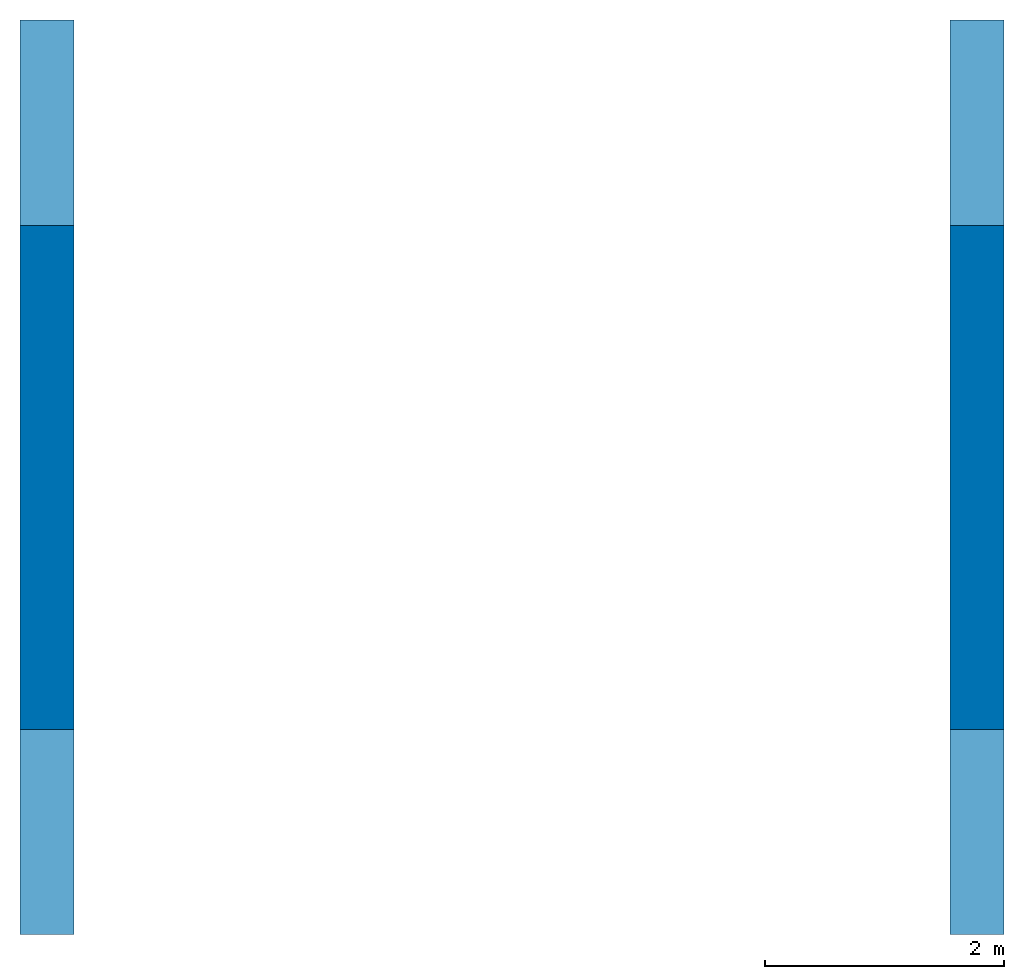
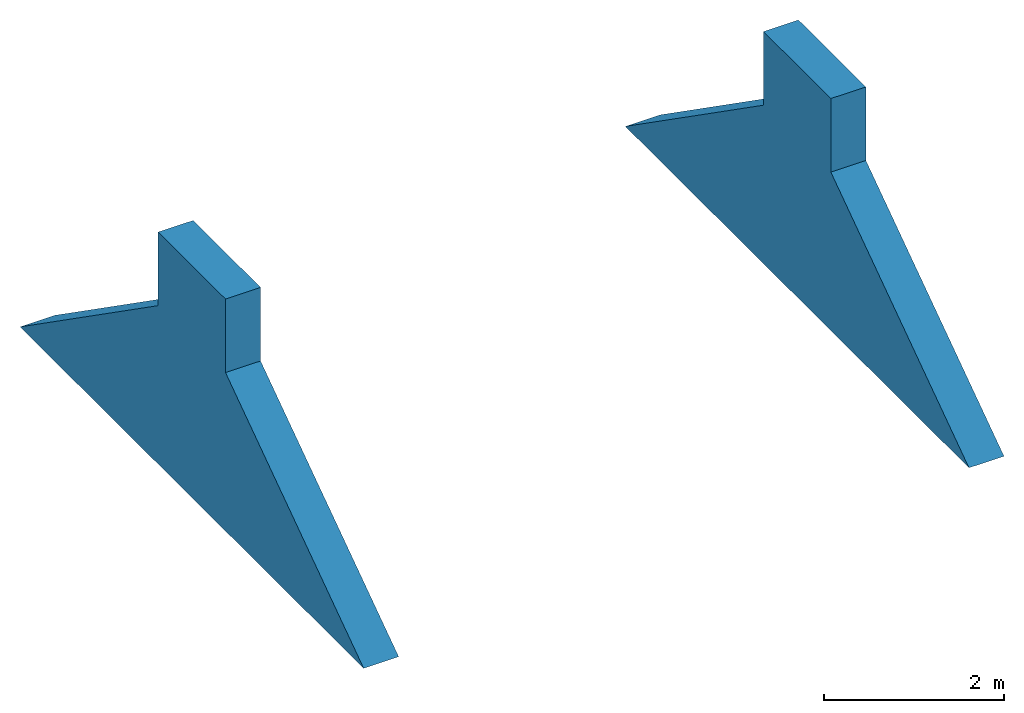
# One storey: 2 walls.
"""IFC4 building model written with IfcOpenShell, lengths in millimetres."""

from ifc_helpers import new_model, entity, si_unit, converted_unit, frame, origin_with_axes, origin_2d_with_axis, place, context, subcontext, project, spatial, polygons, element, save


model = new_model("IFC4")

# Units and contexts
model_context = context("Model", 3, precision=1e-05, world=origin_with_axes())
plan_context = context("Plan", 2, precision=1e-05, world=origin_2d_with_axis())
body_context = subcontext(model_context, "Body", "Model", "MODEL_VIEW")
ifc_project = project(units=[si_unit("VOLUMEUNIT", "CUBIC_METRE"), si_unit("LENGTHUNIT", "METRE", prefix="MILLI"), converted_unit("PLANEANGLEUNIT", "degree", entity("IfcReal", 0.0174532925199433), si_unit("PLANEANGLEUNIT", "RADIAN"), dimensions=[0, 0, 0, 0, 0, 0, 0]), si_unit("AREAUNIT", "SQUARE_METRE")], contexts=[model_context, plan_context])

# Site, building, storey
site_placement = place(None, origin_with_axes())
site = spatial("IfcSite", under=ifc_project, at=site_placement)
building_placement = place(site_placement, origin_with_axes())
building = spatial("IfcBuilding", under=site, at=building_placement, Name="Building")
storey_placement = place(building_placement, frame((0.0, 0.0, 5000.0), z_axis=(0.0, 0.0, 1.0), x_axis=(1.0, 0.0, 0.0)))
storey = spatial("IfcBuildingStorey", under=building, at=storey_placement, Name="Roof")

# Walls
for number, where, z_axis, x_axis in (
    (1, (8780.00164031982, 6650.00009536743, 1000.0), (0.0, 0.0, 1.0), (1.0, 0.0, 0.0)),
    (2, (1000.0, 6650.00009536743, 1000.0), (0.0, 0.0, 1.0), (1.0, 0.0, 0.0)),
):
    element("IfcWall", number, at=place(storey_placement, frame(where, z_axis=z_axis, x_axis=x_axis)), inside=storey, PredefinedType="NOTDEFINED", context=body_context, shape_type="Tessellation", body=[
        polygons([(-1000.0, -6649.99951171875, -1000.0), (-1000.0, -3575.0, 1153.13806152344), (-1000.0, 1000.0, -1000.0), (-1000.0, -2075.00024414062, 1153.13806152344), (-549.999938964844, -6649.99951171875, -1000.0), (-549.999938964844, -3575.0, 1153.13806152344), (-549.999938964844, 1000.0, -1000.0), (-549.999938964844, -2075.00024414062, 1153.13806152344), (-1000.0, -3575.0, 2153.13793945312), (-549.999938964844, -3575.0, 2153.13793945312), (-1000.0, -2075.00048828125, 2153.13818359375), (-549.999938964844, -2075.00048828125, 2153.13818359375)], [[[1, 2, 9, 11, 4, 3]], [[3, 4, 8, 7]], [[7, 8, 12, 10, 6, 5]], [[5, 6, 2, 1]], [[3, 7, 5, 1]], [[10, 9, 2, 6]], [[12, 11, 9, 10]], [[8, 4, 11, 12]]]),
    ])

save(model, "model.ifc")
